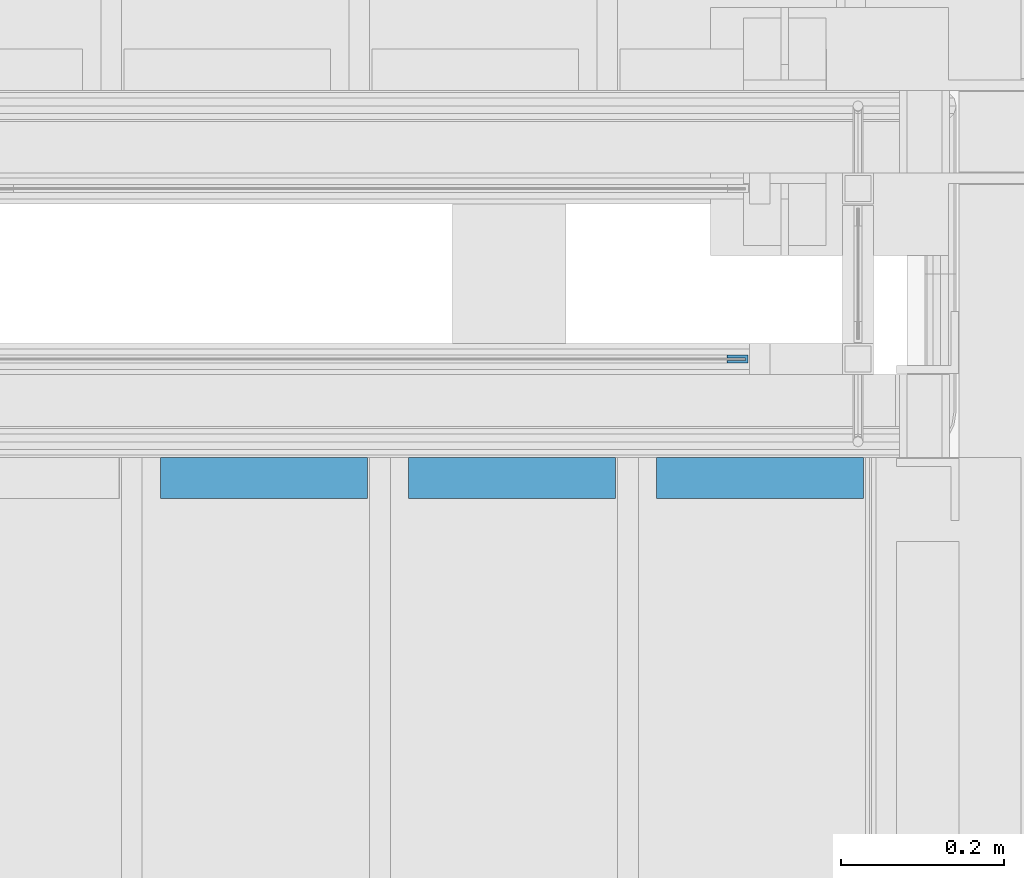
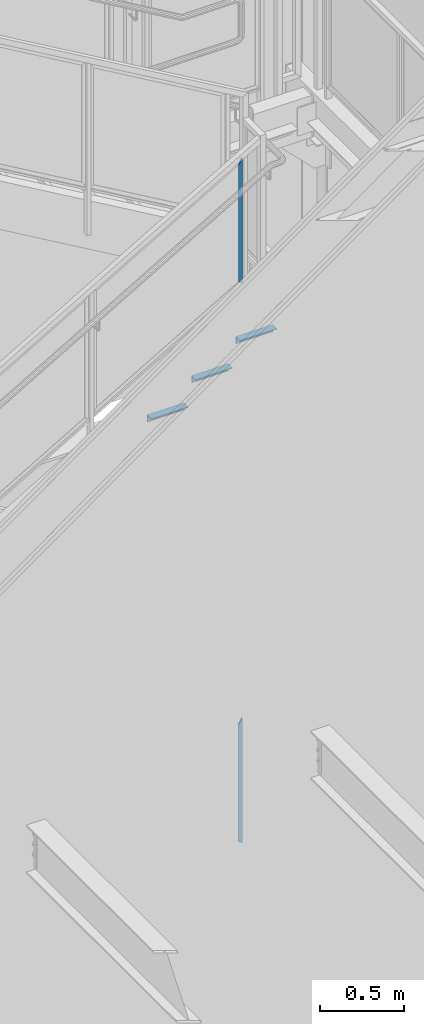
# One storey, part 917 of 1179: 5 beams, 3 elements without a shape of their own.
"""IFC2X3 building model written with IfcOpenShell, lengths in millimetres."""

from ifc_helpers import new_model, si_unit, frame, origin_with_axes, place, context, subcontext, project, spatial, faceted_brep, material, type_object, element, aggregate, save


model = new_model("IFC2X3")

# Units and contexts
model_context = context("Model", 3, precision=1e-05, world=origin_with_axes())
body_context = subcontext(model_context, "Body", "Model", "MODEL_VIEW")
ifc_project = project(units=[si_unit("LENGTHUNIT", "METRE", prefix="MILLI"), si_unit("AREAUNIT", "SQUARE_METRE"), si_unit("VOLUMEUNIT", "CUBIC_METRE"), si_unit("MASSUNIT", "GRAM", prefix="KILO"), si_unit("TIMEUNIT", "SECOND"), si_unit("PLANEANGLEUNIT", "RADIAN"), si_unit("SOLIDANGLEUNIT", "STERADIAN"), si_unit("THERMODYNAMICTEMPERATUREUNIT", "DEGREE_CELSIUS"), si_unit("LUMINOUSINTENSITYUNIT", "LUMEN")], contexts=[model_context])

# Site, building, storey
site_placement = place(None, origin_with_axes())
site = spatial("IfcSite", under=ifc_project, at=site_placement, CompositionType="ELEMENT")
building_placement = place(site_placement, origin_with_axes())
building = spatial("IfcBuilding", under=site, at=building_placement, Name="Undefined", CompositionType="ELEMENT")
storey_placement = place(building_placement, origin_with_axes())
storey = spatial("IfcBuildingStorey", under=building, at=storey_placement, Name="Undefined", CompositionType="ELEMENT", Elevation=0.0)

# Assembly, beam
assembly_1_placement = place(storey_placement, origin_with_axes())
assembly_1 = element("IfcElementAssembly", 1, at=assembly_1_placement, inside=storey, Name="GUARDRAIL", AssemblyPlace="NOTDEFINED", PredefinedType="RIGID_FRAME")
ifc_material_1 = material(Name="STEEL/BUY-OUT")
beam_type_1 = type_object("IfcBeamType", PredefinedType="NOTDEFINED")
beam_1_placement = place(assembly_1_placement, frame((22683.4448480205, 39468.4251646336, 6695.6632679073), z_axis=(0.0, 0.0, -1.0), x_axis=(1.0, 0.0, 0.0)))
beam_1 = element("IfcBeam", 2, at=beam_1_placement, type_object=beam_type_1, material=ifc_material_1, Name="U-EDGE", context=body_context, shape_type="Brep", body=[
    faceted_brep([(6.54836185276508e-11, -4.76249999999709, -409.802660159926), (6.54836185276508e-11, -7.9375, -409.802660159925), (6.54836185276508e-11, -7.9375, 439.435789033928), (6.54836185276508e-11, -4.76249999999709, 439.435789033928), (22.2250000000313, -4.76249999999709, -448.497207519993), (22.2250000000313, -4.76249999999709, 452.20157845494), (22.2250000000313, -1.58750000000146, -448.497207519993), (22.2250000000313, -1.58750000000146, 452.20157845494), (0.0, -1.58750000000146, -409.802660159811), (0.0, -1.58750000000146, 439.43578903389), (0.0, 1.58750000000146, -409.802660159811), (0.0, 1.58750000000146, 439.43578903389), (25.4000000000342, 1.58750000000146, -454.025), (25.4000000000342, 1.58750000000146, 454.025), (25.4000000000342, -7.9375, -454.025), (25.4000000000342, -7.9375, 454.025)], [[[0, 1, 2, 3]], [[4, 0, 3, 5]], [[6, 4, 5, 7]], [[8, 6, 7, 9]], [[10, 8, 9, 11]], [[12, 10, 11, 13]], [[14, 12, 13, 15]], [[11, 9, 7, 5, 3, 2, 15, 13]], [[1, 14, 15, 2]], [[0, 4, 6, 8, 10, 12, 14, 1]]]),
])
aggregate(assembly_1, [beam_1])

assembly_2_placement = place(storey_placement, origin_with_axes())
assembly_2 = element("IfcElementAssembly", 3, at=assembly_2_placement, inside=storey, Name="GUARDRAIL", AssemblyPlace="NOTDEFINED", PredefinedType="RIGID_FRAME")
beam_2_placement = place(assembly_2_placement, frame((22683.7873880621, 39468.4251653905, 2622.82076435014), z_axis=(0.0, 0.0, -1.0), x_axis=(1.0, 0.0, 0.0)))
beam_2 = element("IfcBeam", 4, at=beam_2_placement, type_object=beam_type_1, material=ifc_material_1, Name="U-EDGE", context=body_context, shape_type="Brep", body=[
    faceted_brep([(2.91038304567337e-11, -4.76249999999709, -410.157581087356), (2.91038304567337e-11, -7.9375, -410.157581087356), (2.91038304567337e-11, -7.9375, 440.175143067736), (2.91038304567337e-11, -4.76249999999709, 440.175143067736), (22.2250000000131, -4.76249999999709, -448.707195046795), (22.2250000000131, -4.76249999999709, 452.988518745257), (22.2250000000131, -1.58750000000146, -448.707195046795), (22.2250000000131, -1.58750000000146, 452.988518745257), (0.0, -1.58750000000146, -410.157581087306), (0.0, -1.58750000000146, 440.175143067719), (0.0, 1.58750000000146, -410.157581087305), (0.0, 1.58750000000146, 440.175143067719), (25.400000000016, 1.58750000000146, -454.21428275529), (25.400000000016, 1.58750000000146, 454.819), (25.400000000016, -7.9375, -454.21428275529), (25.400000000016, -7.9375, 454.819)], [[[0, 1, 2, 3]], [[4, 0, 3, 5]], [[6, 4, 5, 7]], [[8, 6, 7, 9]], [[10, 8, 9, 11]], [[12, 10, 11, 13]], [[14, 12, 13, 15]], [[11, 9, 7, 5, 3, 2, 15, 13]], [[1, 14, 15, 2]], [[0, 4, 6, 8, 10, 12, 14, 1]]]),
])
aggregate(assembly_2, [beam_2])

# Assembly, beams
assembly_3_placement = place(storey_placement, origin_with_axes())
assembly_3 = element("IfcElementAssembly", 5, at=assembly_3_placement, inside=storey, Name="STAIR", AssemblyPlace="NOTDEFINED", PredefinedType="RIGID_FRAME")
ifc_material_2 = material(Name="STEEL/A36")
beam_type_2 = type_object("IfcBeamType", Name="L2X2X3/16", PredefinedType="NOTDEFINED")
beam_3_placement = place(assembly_3_placement, frame((22596.8130333856, 39325.5499999802, 5934.67030000019), z_axis=(0.0, -1.0, 0.0), x_axis=(1.0, 0.0, 0.0)))
beam_3 = element("IfcBeam", 6, at=beam_3_placement, type_object=beam_type_2, material=ifc_material_2, Name="ANGLE", ObjectType="L2X2X3/16", context=body_context, shape_type="Brep", body=[
    faceted_brep([(0.0, 25.3999999999996, -25.4000000000015), (0.0, 25.3999999999996, 25.4000000000015), (254.0, 25.3999999999996, 25.4000000000001), (254.0, 25.3999999999996, -25.4000000000001), (0.0, 20.6374999999998, 25.4000000000015), (254.0, 20.6374999999998, 25.4000000000001), (0.0, 20.6374999999998, -20.6374999999971), (254.0, 20.6374999999998, -20.6374999999998), (0.0, -25.3999999999996, -20.6374999999971), (254.0, -25.3999999999996, -20.6374999999998), (0.0, -25.3999999999996, -25.4000000000015), (254.0, -25.3999999999996, -25.4000000000001)], [[[0, 1, 2, 3]], [[1, 4, 5, 2]], [[4, 6, 7, 5]], [[6, 8, 9, 7]], [[8, 10, 11, 9]], [[10, 0, 3, 11]], [[5, 7, 9, 11, 3, 2]], [[10, 8, 6, 4, 1, 0]]]),
])
beam_4_placement = place(assembly_3_placement, frame((22292.0130334085, 39325.5499999802, 5756.87030000019), z_axis=(0.0, -1.0, 0.0), x_axis=(1.0, 0.0, 0.0)))
beam_4 = element("IfcBeam", 7, at=beam_4_placement, type_object=beam_type_2, material=ifc_material_2, Name="ANGLE", ObjectType="L2X2X3/16", context=body_context, shape_type="Brep", body=[
    faceted_brep([(0.0, 25.3999999999996, -25.4000000000015), (0.0, 25.3999999999996, 25.4000000000015), (254.0, 25.3999999999996, 25.4000000000001), (254.0, 25.3999999999996, -25.4000000000001), (0.0, 20.6374999999998, 25.4000000000015), (254.0, 20.6374999999998, 25.4000000000001), (0.0, 20.6374999999998, -20.6374999999971), (254.0, 20.6374999999998, -20.6374999999998), (0.0, -25.3999999999996, -20.6374999999971), (254.0, -25.3999999999996, -20.6374999999998), (0.0, -25.3999999999996, -25.4000000000015), (254.0, -25.3999999999996, -25.4000000000001)], [[[0, 1, 2, 3]], [[1, 4, 5, 2]], [[4, 6, 7, 5]], [[6, 8, 9, 7]], [[8, 10, 11, 9]], [[10, 0, 3, 11]], [[5, 7, 9, 11, 3, 2]], [[10, 8, 6, 4, 1, 0]]]),
])
beam_5_placement = place(assembly_3_placement, frame((21987.2130334314, 39325.5499999802, 5579.07030000019), z_axis=(0.0, -1.0, 0.0), x_axis=(1.0, 0.0, 0.0)))
beam_5 = element("IfcBeam", 8, at=beam_5_placement, type_object=beam_type_2, material=ifc_material_2, Name="ANGLE", ObjectType="L2X2X3/16", context=body_context, shape_type="Brep", body=[
    faceted_brep([(0.0, 25.3999999999996, -25.4000000000015), (0.0, 25.3999999999996, 25.4000000000015), (254.0, 25.3999999999996, 25.4000000000001), (254.0, 25.3999999999996, -25.4000000000001), (0.0, 20.6374999999998, 25.4000000000015), (254.0, 20.6374999999998, 25.4000000000001), (0.0, 20.6374999999998, -20.6374999999971), (254.0, 20.6374999999998, -20.6374999999998), (0.0, -25.3999999999996, -20.6374999999971), (254.0, -25.3999999999996, -20.6374999999998), (0.0, -25.3999999999996, -25.4000000000015), (254.0, -25.3999999999996, -25.4000000000001)], [[[0, 1, 2, 3]], [[1, 4, 5, 2]], [[4, 6, 7, 5]], [[6, 8, 9, 7]], [[8, 10, 11, 9]], [[10, 0, 3, 11]], [[5, 7, 9, 11, 3, 2]], [[10, 8, 6, 4, 1, 0]]]),
])
aggregate(assembly_3, [beam_3, beam_4, beam_5])

save(model, "model.ifc")
